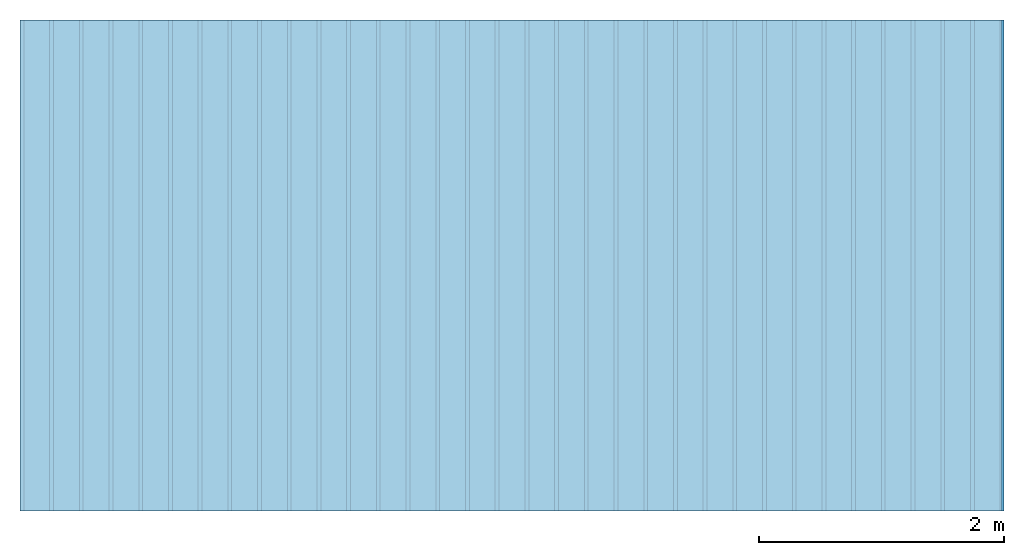
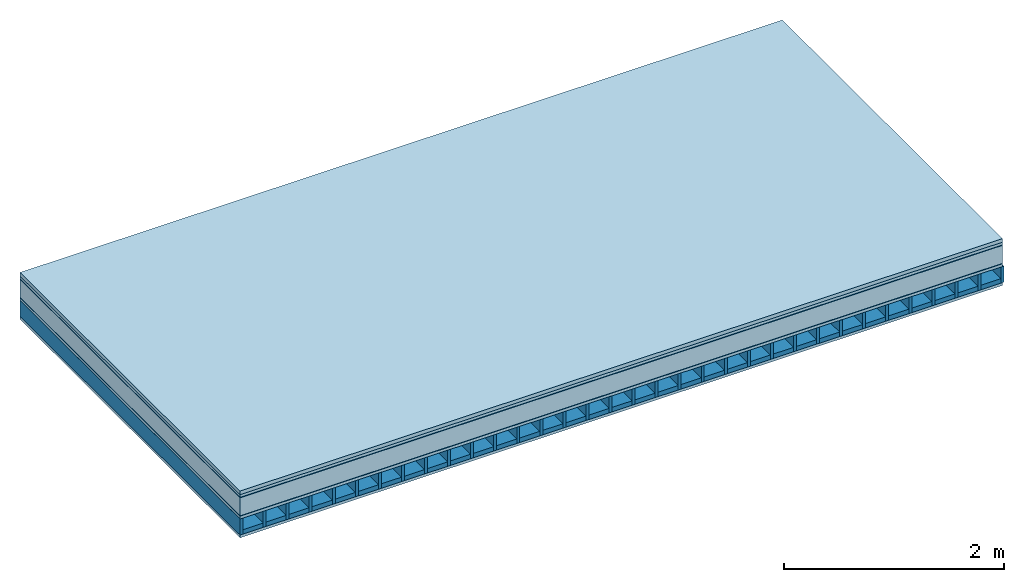
# One storey: 7 plates, 2 members, 1 element without a shape of its own.
"""IFC4 building model written with IfcOpenShell, lengths in metres."""

from ifc_helpers import new_model, si_unit, derived_unit, direction, frame, frame_2d, origin, origin_with_axes, place, context, project, spatial, rectangle, extrude, material, layer, layer_set, type_object, element, aggregate, save


model = new_model("IFC4")

# Units and contexts
plan_context = context("Plan", 3, precision=1e-05, world=origin(), true_north=direction((0.0, 1.0)))
model_context = context("Model", 3, precision=1e-05, world=origin(), true_north=direction((0.0, 1.0)))
ifc_project = project(units=[si_unit("LENGTHUNIT", "METRE"), derived_unit("SOUNDPRESSUREUNIT", [(si_unit("PRESSUREUNIT", "PASCAL", prefix="MICRO"), 0)]), si_unit("ENERGYUNIT", "JOULE", prefix="MEGA"), si_unit("MASSUNIT", "GRAM", prefix="KILO"), derived_unit("THERMALTRANSMITTANCEUNIT", [(si_unit("POWERUNIT", "WATT"), 1), (si_unit("AREAUNIT", "SQUARE_METRE"), -1), (si_unit("THERMODYNAMICTEMPERATUREUNIT", "KELVIN"), -1)]), derived_unit("AREADENSITYUNIT", [(si_unit("MASSUNIT", "GRAM", prefix="KILO"), 1), (si_unit("AREAUNIT", "SQUARE_METRE"), -1)]), derived_unit("USERDEFINED", [(si_unit("ENERGYUNIT", "JOULE", prefix="MEGA"), 1), (si_unit("AREAUNIT", "SQUARE_METRE"), -1)])], contexts=[plan_context, model_context])

# Site, building, storey
site = spatial("IfcSite", under=ifc_project)
building_placement = place(None, origin())
building = spatial("IfcBuilding", under=site, at=building_placement)
storey_placement = place(building_placement, origin())
storey = spatial("IfcBuildingStorey", under=building, at=storey_placement)

# Slab, members, plates
ifc_material_1 = material(Name="Garden plates", Category="02.007")
ifc_layer_1 = layer(ifc_material_1, 0.04, Name="Use and protection layer 2")
ifc_material_2 = material(Name="Fine gravel 3-6 mm", Category="03.011")
ifc_layer_2 = layer(ifc_material_2, 0.03, Name="Use and protection layer 1")
ifc_material_3 = material(Name="Roofing underlay", Category="09.008")
ifc_layer_3 = layer(ifc_material_3, 0.005, Name="Under the roof")
ifc_material_4 = material(Category="10.004")
ifc_layer_4 = layer(ifc_material_4, 0.2, Name="Exterior insulation layer 1")
ifc_material_5 = material(Name="Vapor barrier bituminous", Category="09.003")
ifc_layer_5 = layer(ifc_material_5, 0.004, Name="layer / temporary roof")
ifc_material_6 = material(Name="surface element sheathing above")
ifc_layer_6 = layer(ifc_material_6, 0.031, Name="above 1st layer")
ifc_layer_7 = layer(None, 0.178, Name="Support")
ifc_material_7 = material(Name="surface element sheathing below")
ifc_layer_8 = layer(ifc_material_7, 0.031, Name="Lower layer 1")
ifc_layer_set = layer_set([ifc_layer_1, ifc_layer_2, ifc_layer_3, ifc_layer_4, ifc_layer_5, ifc_layer_6, ifc_layer_7, ifc_layer_8])
slab_type = type_object("IfcSlabType", Name="F0121", PredefinedType="NOTDEFINED", material=ifc_layer_set)
slab_placement = place(None, frame((0.0, 0.0, 0.0), z_axis=(0.0, 0.0, -1.0), x_axis=(1.0, 0.0, 0.0)))
slab = element("IfcSlab", 1, at=slab_placement, inside=storey, type_object=slab_type, material=ifc_layer_set, Name="Slab #1")
ifc_material_8 = material(Name="surface element LFE")
member_1_placement = place(slab_placement, origin())
member_1 = element("IfcMember", 2, at=member_1_placement, material=ifc_material_8, Name="Support", context=plan_context, shape_type="SweptSolid", body=[
    extrude(rectangle(XDim=0.031, YDim=0.178, at=frame_2d((0.0155, 0.089), x_axis=(1.0, 0.0))), frame((0.0, 4.0, 0.31), z_axis=(0.0, -1.0, 0.0), x_axis=(1.0, 0.0, 0.0)), (0.0, 0.0, 1.0), 4.0),
    extrude(rectangle(XDim=0.031, YDim=0.178, at=frame_2d((0.0155, 0.089), x_axis=(1.0, 0.0))), frame((0.242, 4.0, 0.31), z_axis=(0.0, -1.0, 0.0), x_axis=(1.0, 0.0, 0.0)), (0.0, 0.0, 1.0), 4.0),
    extrude(rectangle(XDim=0.031, YDim=0.178, at=frame_2d((0.0155, 0.089), x_axis=(1.0, 0.0))), frame((0.484, 4.0, 0.31), z_axis=(0.0, -1.0, 0.0), x_axis=(1.0, 0.0, 0.0)), (0.0, 0.0, 1.0), 4.0),
    extrude(rectangle(XDim=0.031, YDim=0.178, at=frame_2d((0.0155, 0.089), x_axis=(1.0, 0.0))), frame((0.726, 4.0, 0.31), z_axis=(0.0, -1.0, 0.0), x_axis=(1.0, 0.0, 0.0)), (0.0, 0.0, 1.0), 4.0),
    extrude(rectangle(XDim=0.031, YDim=0.178, at=frame_2d((0.0155, 0.089), x_axis=(1.0, 0.0))), frame((0.968, 4.0, 0.31), z_axis=(0.0, -1.0, 0.0), x_axis=(1.0, 0.0, 0.0)), (0.0, 0.0, 1.0), 4.0),
    extrude(rectangle(XDim=0.031, YDim=0.178, at=frame_2d((0.0155, 0.089), x_axis=(1.0, 0.0))), frame((1.21, 4.0, 0.31), z_axis=(0.0, -1.0, 0.0), x_axis=(1.0, 0.0, 0.0)), (0.0, 0.0, 1.0), 4.0),
    extrude(rectangle(XDim=0.031, YDim=0.178, at=frame_2d((0.0155, 0.089), x_axis=(1.0, 0.0))), frame((1.452, 4.0, 0.31), z_axis=(0.0, -1.0, 0.0), x_axis=(1.0, 0.0, 0.0)), (0.0, 0.0, 1.0), 4.0),
    extrude(rectangle(XDim=0.031, YDim=0.178, at=frame_2d((0.0155, 0.089), x_axis=(1.0, 0.0))), frame((1.694, 4.0, 0.31), z_axis=(0.0, -1.0, 0.0), x_axis=(1.0, 0.0, 0.0)), (0.0, 0.0, 1.0), 4.0),
    extrude(rectangle(XDim=0.031, YDim=0.178, at=frame_2d((0.0155, 0.089), x_axis=(1.0, 0.0))), frame((1.936, 4.0, 0.31), z_axis=(0.0, -1.0, 0.0), x_axis=(1.0, 0.0, 0.0)), (0.0, 0.0, 1.0), 4.0),
    extrude(rectangle(XDim=0.031, YDim=0.178, at=frame_2d((0.0155, 0.089), x_axis=(1.0, 0.0))), frame((2.178, 4.0, 0.31), z_axis=(0.0, -1.0, 0.0), x_axis=(1.0, 0.0, 0.0)), (0.0, 0.0, 1.0), 4.0),
    extrude(rectangle(XDim=0.031, YDim=0.178, at=frame_2d((0.0155, 0.089), x_axis=(1.0, 0.0))), frame((2.42, 4.0, 0.31), z_axis=(0.0, -1.0, 0.0), x_axis=(1.0, 0.0, 0.0)), (0.0, 0.0, 1.0), 4.0),
    extrude(rectangle(XDim=0.031, YDim=0.178, at=frame_2d((0.0155, 0.089), x_axis=(1.0, 0.0))), frame((2.662, 4.0, 0.31), z_axis=(0.0, -1.0, 0.0), x_axis=(1.0, 0.0, 0.0)), (0.0, 0.0, 1.0), 4.0),
    extrude(rectangle(XDim=0.031, YDim=0.178, at=frame_2d((0.0155, 0.089), x_axis=(1.0, 0.0))), frame((2.904, 4.0, 0.31), z_axis=(0.0, -1.0, 0.0), x_axis=(1.0, 0.0, 0.0)), (0.0, 0.0, 1.0), 4.0),
    extrude(rectangle(XDim=0.031, YDim=0.178, at=frame_2d((0.0155, 0.089), x_axis=(1.0, 0.0))), frame((3.146, 4.0, 0.31), z_axis=(0.0, -1.0, 0.0), x_axis=(1.0, 0.0, 0.0)), (0.0, 0.0, 1.0), 4.0),
    extrude(rectangle(XDim=0.031, YDim=0.178, at=frame_2d((0.0155, 0.089), x_axis=(1.0, 0.0))), frame((3.388, 4.0, 0.31), z_axis=(0.0, -1.0, 0.0), x_axis=(1.0, 0.0, 0.0)), (0.0, 0.0, 1.0), 4.0),
    extrude(rectangle(XDim=0.031, YDim=0.178, at=frame_2d((0.0155, 0.089), x_axis=(1.0, 0.0))), frame((3.63, 4.0, 0.31), z_axis=(0.0, -1.0, 0.0), x_axis=(1.0, 0.0, 0.0)), (0.0, 0.0, 1.0), 4.0),
    extrude(rectangle(XDim=0.031, YDim=0.178, at=frame_2d((0.0155, 0.089), x_axis=(1.0, 0.0))), frame((3.872, 4.0, 0.31), z_axis=(0.0, -1.0, 0.0), x_axis=(1.0, 0.0, 0.0)), (0.0, 0.0, 1.0), 4.0),
    extrude(rectangle(XDim=0.031, YDim=0.178, at=frame_2d((0.0155, 0.089), x_axis=(1.0, 0.0))), frame((4.114, 4.0, 0.31), z_axis=(0.0, -1.0, 0.0), x_axis=(1.0, 0.0, 0.0)), (0.0, 0.0, 1.0), 4.0),
    extrude(rectangle(XDim=0.031, YDim=0.178, at=frame_2d((0.0155, 0.089), x_axis=(1.0, 0.0))), frame((4.356, 4.0, 0.31), z_axis=(0.0, -1.0, 0.0), x_axis=(1.0, 0.0, 0.0)), (0.0, 0.0, 1.0), 4.0),
    extrude(rectangle(XDim=0.031, YDim=0.178, at=frame_2d((0.0155, 0.089), x_axis=(1.0, 0.0))), frame((4.598, 4.0, 0.31), z_axis=(0.0, -1.0, 0.0), x_axis=(1.0, 0.0, 0.0)), (0.0, 0.0, 1.0), 4.0),
    extrude(rectangle(XDim=0.031, YDim=0.178, at=frame_2d((0.0155, 0.089), x_axis=(1.0, 0.0))), frame((4.84, 4.0, 0.31), z_axis=(0.0, -1.0, 0.0), x_axis=(1.0, 0.0, 0.0)), (0.0, 0.0, 1.0), 4.0),
    extrude(rectangle(XDim=0.031, YDim=0.178, at=frame_2d((0.0155, 0.089), x_axis=(1.0, 0.0))), frame((5.082, 4.0, 0.31), z_axis=(0.0, -1.0, 0.0), x_axis=(1.0, 0.0, 0.0)), (0.0, 0.0, 1.0), 4.0),
    extrude(rectangle(XDim=0.031, YDim=0.178, at=frame_2d((0.0155, 0.089), x_axis=(1.0, 0.0))), frame((5.324, 4.0, 0.31), z_axis=(0.0, -1.0, 0.0), x_axis=(1.0, 0.0, 0.0)), (0.0, 0.0, 1.0), 4.0),
    extrude(rectangle(XDim=0.031, YDim=0.178, at=frame_2d((0.0155, 0.089), x_axis=(1.0, 0.0))), frame((5.566, 4.0, 0.31), z_axis=(0.0, -1.0, 0.0), x_axis=(1.0, 0.0, 0.0)), (0.0, 0.0, 1.0), 4.0),
    extrude(rectangle(XDim=0.031, YDim=0.178, at=frame_2d((0.0155, 0.089), x_axis=(1.0, 0.0))), frame((5.808, 4.0, 0.31), z_axis=(0.0, -1.0, 0.0), x_axis=(1.0, 0.0, 0.0)), (0.0, 0.0, 1.0), 4.0),
    extrude(rectangle(XDim=0.031, YDim=0.178, at=frame_2d((0.0155, 0.089), x_axis=(1.0, 0.0))), frame((6.05, 4.0, 0.31), z_axis=(0.0, -1.0, 0.0), x_axis=(1.0, 0.0, 0.0)), (0.0, 0.0, 1.0), 4.0),
    extrude(rectangle(XDim=0.031, YDim=0.178, at=frame_2d((0.0155, 0.089), x_axis=(1.0, 0.0))), frame((6.292, 4.0, 0.31), z_axis=(0.0, -1.0, 0.0), x_axis=(1.0, 0.0, 0.0)), (0.0, 0.0, 1.0), 4.0),
    extrude(rectangle(XDim=0.031, YDim=0.178, at=frame_2d((0.0155, 0.089), x_axis=(1.0, 0.0))), frame((6.534, 4.0, 0.31), z_axis=(0.0, -1.0, 0.0), x_axis=(1.0, 0.0, 0.0)), (0.0, 0.0, 1.0), 4.0),
    extrude(rectangle(XDim=0.031, YDim=0.178, at=frame_2d((0.0155, 0.089), x_axis=(1.0, 0.0))), frame((6.776, 4.0, 0.31), z_axis=(0.0, -1.0, 0.0), x_axis=(1.0, 0.0, 0.0)), (0.0, 0.0, 1.0), 4.0),
    extrude(rectangle(XDim=0.031, YDim=0.178, at=frame_2d((0.0155, 0.089), x_axis=(1.0, 0.0))), frame((7.018, 4.0, 0.31), z_axis=(0.0, -1.0, 0.0), x_axis=(1.0, 0.0, 0.0)), (0.0, 0.0, 1.0), 4.0),
    extrude(rectangle(XDim=0.031, YDim=0.178, at=frame_2d((0.0155, 0.089), x_axis=(1.0, 0.0))), frame((7.26, 4.0, 0.31), z_axis=(0.0, -1.0, 0.0), x_axis=(1.0, 0.0, 0.0)), (0.0, 0.0, 1.0), 4.0),
    extrude(rectangle(XDim=0.031, YDim=0.178, at=frame_2d((0.0155, 0.089), x_axis=(1.0, 0.0))), frame((7.502, 4.0, 0.31), z_axis=(0.0, -1.0, 0.0), x_axis=(1.0, 0.0, 0.0)), (0.0, 0.0, 1.0), 4.0),
    extrude(rectangle(XDim=0.031, YDim=0.178, at=frame_2d((0.0155, 0.089), x_axis=(1.0, 0.0))), frame((7.744, 4.0, 0.31), z_axis=(0.0, -1.0, 0.0), x_axis=(1.0, 0.0, 0.0)), (0.0, 0.0, 1.0), 4.0),
    extrude(rectangle(XDim=0.031, YDim=0.178, at=frame_2d((0.0155, 0.089), x_axis=(1.0, 0.0))), frame((7.986, 4.0, 0.31), z_axis=(0.0, -1.0, 0.0), x_axis=(1.0, 0.0, 0.0)), (0.0, 0.0, 1.0), 4.0),
])
ifc_material_9 = material()
member_2_placement = place(slab_placement, origin())
member_2 = element("IfcMember", 3, at=member_2_placement, material=ifc_material_9, Name="in supporting structure", context=plan_context, shape_type="SweptSolid", body=[
    extrude(rectangle(XDim=0.211, YDim=0.049, at=frame_2d((0.1055, 0.0245), x_axis=(1.0, 0.0))), frame((0.031, 4.0, 0.439), z_axis=(0.0, -1.0, 0.0), x_axis=(1.0, 0.0, 0.0)), (0.0, 0.0, 1.0), 4.0),
    extrude(rectangle(XDim=0.211, YDim=0.049, at=frame_2d((0.1055, 0.0245), x_axis=(1.0, 0.0))), frame((0.273, 4.0, 0.439), z_axis=(0.0, -1.0, 0.0), x_axis=(1.0, 0.0, 0.0)), (0.0, 0.0, 1.0), 4.0),
    extrude(rectangle(XDim=0.211, YDim=0.049, at=frame_2d((0.1055, 0.0245), x_axis=(1.0, 0.0))), frame((0.515, 4.0, 0.439), z_axis=(0.0, -1.0, 0.0), x_axis=(1.0, 0.0, 0.0)), (0.0, 0.0, 1.0), 4.0),
    extrude(rectangle(XDim=0.211, YDim=0.049, at=frame_2d((0.1055, 0.0245), x_axis=(1.0, 0.0))), frame((0.757, 4.0, 0.439), z_axis=(0.0, -1.0, 0.0), x_axis=(1.0, 0.0, 0.0)), (0.0, 0.0, 1.0), 4.0),
    extrude(rectangle(XDim=0.211, YDim=0.049, at=frame_2d((0.1055, 0.0245), x_axis=(1.0, 0.0))), frame((0.999, 4.0, 0.439), z_axis=(0.0, -1.0, 0.0), x_axis=(1.0, 0.0, 0.0)), (0.0, 0.0, 1.0), 4.0),
    extrude(rectangle(XDim=0.211, YDim=0.049, at=frame_2d((0.1055, 0.0245), x_axis=(1.0, 0.0))), frame((1.241, 4.0, 0.439), z_axis=(0.0, -1.0, 0.0), x_axis=(1.0, 0.0, 0.0)), (0.0, 0.0, 1.0), 4.0),
    extrude(rectangle(XDim=0.211, YDim=0.049, at=frame_2d((0.1055, 0.0245), x_axis=(1.0, 0.0))), frame((1.483, 4.0, 0.439), z_axis=(0.0, -1.0, 0.0), x_axis=(1.0, 0.0, 0.0)), (0.0, 0.0, 1.0), 4.0),
    extrude(rectangle(XDim=0.211, YDim=0.049, at=frame_2d((0.1055, 0.0245), x_axis=(1.0, 0.0))), frame((1.725, 4.0, 0.439), z_axis=(0.0, -1.0, 0.0), x_axis=(1.0, 0.0, 0.0)), (0.0, 0.0, 1.0), 4.0),
    extrude(rectangle(XDim=0.211, YDim=0.049, at=frame_2d((0.1055, 0.0245), x_axis=(1.0, 0.0))), frame((1.967, 4.0, 0.439), z_axis=(0.0, -1.0, 0.0), x_axis=(1.0, 0.0, 0.0)), (0.0, 0.0, 1.0), 4.0),
    extrude(rectangle(XDim=0.211, YDim=0.049, at=frame_2d((0.1055, 0.0245), x_axis=(1.0, 0.0))), frame((2.209, 4.0, 0.439), z_axis=(0.0, -1.0, 0.0), x_axis=(1.0, 0.0, 0.0)), (0.0, 0.0, 1.0), 4.0),
    extrude(rectangle(XDim=0.211, YDim=0.049, at=frame_2d((0.1055, 0.0245), x_axis=(1.0, 0.0))), frame((2.451, 4.0, 0.439), z_axis=(0.0, -1.0, 0.0), x_axis=(1.0, 0.0, 0.0)), (0.0, 0.0, 1.0), 4.0),
    extrude(rectangle(XDim=0.211, YDim=0.049, at=frame_2d((0.1055, 0.0245), x_axis=(1.0, 0.0))), frame((2.693, 4.0, 0.439), z_axis=(0.0, -1.0, 0.0), x_axis=(1.0, 0.0, 0.0)), (0.0, 0.0, 1.0), 4.0),
    extrude(rectangle(XDim=0.211, YDim=0.049, at=frame_2d((0.1055, 0.0245), x_axis=(1.0, 0.0))), frame((2.935, 4.0, 0.439), z_axis=(0.0, -1.0, 0.0), x_axis=(1.0, 0.0, 0.0)), (0.0, 0.0, 1.0), 4.0),
    extrude(rectangle(XDim=0.211, YDim=0.049, at=frame_2d((0.1055, 0.0245), x_axis=(1.0, 0.0))), frame((3.177, 4.0, 0.439), z_axis=(0.0, -1.0, 0.0), x_axis=(1.0, 0.0, 0.0)), (0.0, 0.0, 1.0), 4.0),
    extrude(rectangle(XDim=0.211, YDim=0.049, at=frame_2d((0.1055, 0.0245), x_axis=(1.0, 0.0))), frame((3.419, 4.0, 0.439), z_axis=(0.0, -1.0, 0.0), x_axis=(1.0, 0.0, 0.0)), (0.0, 0.0, 1.0), 4.0),
    extrude(rectangle(XDim=0.211, YDim=0.049, at=frame_2d((0.1055, 0.0245), x_axis=(1.0, 0.0))), frame((3.661, 4.0, 0.439), z_axis=(0.0, -1.0, 0.0), x_axis=(1.0, 0.0, 0.0)), (0.0, 0.0, 1.0), 4.0),
    extrude(rectangle(XDim=0.211, YDim=0.049, at=frame_2d((0.1055, 0.0245), x_axis=(1.0, 0.0))), frame((3.903, 4.0, 0.439), z_axis=(0.0, -1.0, 0.0), x_axis=(1.0, 0.0, 0.0)), (0.0, 0.0, 1.0), 4.0),
    extrude(rectangle(XDim=0.211, YDim=0.049, at=frame_2d((0.1055, 0.0245), x_axis=(1.0, 0.0))), frame((4.145, 4.0, 0.439), z_axis=(0.0, -1.0, 0.0), x_axis=(1.0, 0.0, 0.0)), (0.0, 0.0, 1.0), 4.0),
    extrude(rectangle(XDim=0.211, YDim=0.049, at=frame_2d((0.1055, 0.0245), x_axis=(1.0, 0.0))), frame((4.387, 4.0, 0.439), z_axis=(0.0, -1.0, 0.0), x_axis=(1.0, 0.0, 0.0)), (0.0, 0.0, 1.0), 4.0),
    extrude(rectangle(XDim=0.211, YDim=0.049, at=frame_2d((0.1055, 0.0245), x_axis=(1.0, 0.0))), frame((4.629, 4.0, 0.439), z_axis=(0.0, -1.0, 0.0), x_axis=(1.0, 0.0, 0.0)), (0.0, 0.0, 1.0), 4.0),
    extrude(rectangle(XDim=0.211, YDim=0.049, at=frame_2d((0.1055, 0.0245), x_axis=(1.0, 0.0))), frame((4.871, 4.0, 0.439), z_axis=(0.0, -1.0, 0.0), x_axis=(1.0, 0.0, 0.0)), (0.0, 0.0, 1.0), 4.0),
    extrude(rectangle(XDim=0.211, YDim=0.049, at=frame_2d((0.1055, 0.0245), x_axis=(1.0, 0.0))), frame((5.113, 4.0, 0.439), z_axis=(0.0, -1.0, 0.0), x_axis=(1.0, 0.0, 0.0)), (0.0, 0.0, 1.0), 4.0),
    extrude(rectangle(XDim=0.211, YDim=0.049, at=frame_2d((0.1055, 0.0245), x_axis=(1.0, 0.0))), frame((5.355, 4.0, 0.439), z_axis=(0.0, -1.0, 0.0), x_axis=(1.0, 0.0, 0.0)), (0.0, 0.0, 1.0), 4.0),
    extrude(rectangle(XDim=0.211, YDim=0.049, at=frame_2d((0.1055, 0.0245), x_axis=(1.0, 0.0))), frame((5.597, 4.0, 0.439), z_axis=(0.0, -1.0, 0.0), x_axis=(1.0, 0.0, 0.0)), (0.0, 0.0, 1.0), 4.0),
    extrude(rectangle(XDim=0.211, YDim=0.049, at=frame_2d((0.1055, 0.0245), x_axis=(1.0, 0.0))), frame((5.839, 4.0, 0.439), z_axis=(0.0, -1.0, 0.0), x_axis=(1.0, 0.0, 0.0)), (0.0, 0.0, 1.0), 4.0),
    extrude(rectangle(XDim=0.211, YDim=0.049, at=frame_2d((0.1055, 0.0245), x_axis=(1.0, 0.0))), frame((6.081, 4.0, 0.439), z_axis=(0.0, -1.0, 0.0), x_axis=(1.0, 0.0, 0.0)), (0.0, 0.0, 1.0), 4.0),
    extrude(rectangle(XDim=0.211, YDim=0.049, at=frame_2d((0.1055, 0.0245), x_axis=(1.0, 0.0))), frame((6.323, 4.0, 0.439), z_axis=(0.0, -1.0, 0.0), x_axis=(1.0, 0.0, 0.0)), (0.0, 0.0, 1.0), 4.0),
    extrude(rectangle(XDim=0.211, YDim=0.049, at=frame_2d((0.1055, 0.0245), x_axis=(1.0, 0.0))), frame((6.565, 4.0, 0.439), z_axis=(0.0, -1.0, 0.0), x_axis=(1.0, 0.0, 0.0)), (0.0, 0.0, 1.0), 4.0),
    extrude(rectangle(XDim=0.211, YDim=0.049, at=frame_2d((0.1055, 0.0245), x_axis=(1.0, 0.0))), frame((6.807, 4.0, 0.439), z_axis=(0.0, -1.0, 0.0), x_axis=(1.0, 0.0, 0.0)), (0.0, 0.0, 1.0), 4.0),
    extrude(rectangle(XDim=0.211, YDim=0.049, at=frame_2d((0.1055, 0.0245), x_axis=(1.0, 0.0))), frame((7.049, 4.0, 0.439), z_axis=(0.0, -1.0, 0.0), x_axis=(1.0, 0.0, 0.0)), (0.0, 0.0, 1.0), 4.0),
    extrude(rectangle(XDim=0.211, YDim=0.049, at=frame_2d((0.1055, 0.0245), x_axis=(1.0, 0.0))), frame((7.291, 4.0, 0.439), z_axis=(0.0, -1.0, 0.0), x_axis=(1.0, 0.0, 0.0)), (0.0, 0.0, 1.0), 4.0),
    extrude(rectangle(XDim=0.211, YDim=0.049, at=frame_2d((0.1055, 0.0245), x_axis=(1.0, 0.0))), frame((7.533, 4.0, 0.439), z_axis=(0.0, -1.0, 0.0), x_axis=(1.0, 0.0, 0.0)), (0.0, 0.0, 1.0), 4.0),
    extrude(rectangle(XDim=0.211, YDim=0.049, at=frame_2d((0.1055, 0.0245), x_axis=(1.0, 0.0))), frame((7.775, 4.0, 0.439), z_axis=(0.0, -1.0, 0.0), x_axis=(1.0, 0.0, 0.0)), (0.0, 0.0, 1.0), 4.0),
])
plate_1_placement = place(slab_placement, origin())
plate_1 = element("IfcPlate", 4, at=plate_1_placement, material=ifc_material_1, Name="Use and protection layer 2", context=plan_context, shape_type="SweptSolid", body=[
    extrude(rectangle(XDim=8.0, YDim=4.0, at=frame_2d((4.0, 2.0), x_axis=(1.0, 0.0))), origin_with_axes(), (0.0, 0.0, 1.0), 0.04),
])
plate_2_placement = place(slab_placement, origin())
plate_2 = element("IfcPlate", 5, at=plate_2_placement, material=ifc_material_2, Name="Use and protection layer 1", context=plan_context, shape_type="SweptSolid", body=[
    extrude(rectangle(XDim=8.0, YDim=4.0, at=frame_2d((4.0, 2.0), x_axis=(1.0, 0.0))), frame((0.0, 0.0, 0.04), z_axis=(0.0, 0.0, 1.0), x_axis=(1.0, 0.0, 0.0)), (0.0, 0.0, 1.0), 0.03),
])
plate_3_placement = place(slab_placement, origin())
plate_3 = element("IfcPlate", 6, at=plate_3_placement, material=ifc_material_3, Name="Under the roof", context=plan_context, shape_type="SweptSolid", body=[
    extrude(rectangle(XDim=8.0, YDim=4.0, at=frame_2d((4.0, 2.0), x_axis=(1.0, 0.0))), frame((0.0, 0.0, 0.07), z_axis=(0.0, 0.0, 1.0), x_axis=(1.0, 0.0, 0.0)), (0.0, 0.0, 1.0), 0.005),
])
plate_4_placement = place(slab_placement, origin())
plate_4 = element("IfcPlate", 7, at=plate_4_placement, material=ifc_material_4, Name="Exterior insulation layer 1", context=plan_context, shape_type="SweptSolid", body=[
    extrude(rectangle(XDim=8.0, YDim=4.0, at=frame_2d((4.0, 2.0), x_axis=(1.0, 0.0))), frame((0.0, 0.0, 0.075), z_axis=(0.0, 0.0, 1.0), x_axis=(1.0, 0.0, 0.0)), (0.0, 0.0, 1.0), 0.2),
])
plate_5_placement = place(slab_placement, origin())
plate_5 = element("IfcPlate", 8, at=plate_5_placement, material=ifc_material_5, Name="layer / temporary roof", context=plan_context, shape_type="SweptSolid", body=[
    extrude(rectangle(XDim=8.0, YDim=4.0, at=frame_2d((4.0, 2.0), x_axis=(1.0, 0.0))), frame((0.0, 0.0, 0.275), z_axis=(0.0, 0.0, 1.0), x_axis=(1.0, 0.0, 0.0)), (0.0, 0.0, 1.0), 0.004),
])
plate_6_placement = place(slab_placement, origin())
plate_6 = element("IfcPlate", 9, at=plate_6_placement, material=ifc_material_6, Name="above 1st layer", context=plan_context, shape_type="SweptSolid", body=[
    extrude(rectangle(XDim=8.0, YDim=4.0, at=frame_2d((4.0, 2.0), x_axis=(1.0, 0.0))), frame((0.0, 0.0, 0.279), z_axis=(0.0, 0.0, 1.0), x_axis=(1.0, 0.0, 0.0)), (0.0, 0.0, 1.0), 0.031),
])
plate_7_placement = place(slab_placement, origin())
plate_7 = element("IfcPlate", 10, at=plate_7_placement, material=ifc_material_7, Name="Lower layer 1", context=plan_context, shape_type="SweptSolid", body=[
    extrude(rectangle(XDim=8.0, YDim=4.0, at=frame_2d((4.0, 2.0), x_axis=(1.0, 0.0))), frame((0.0, 0.0, 0.488), z_axis=(0.0, 0.0, 1.0), x_axis=(1.0, 0.0, 0.0)), (0.0, 0.0, 1.0), 0.031),
])
aggregate(slab, [plate_1, plate_2, plate_3, plate_4, plate_5, plate_6, member_1, member_2, plate_7])

save(model, "model.ifc")
